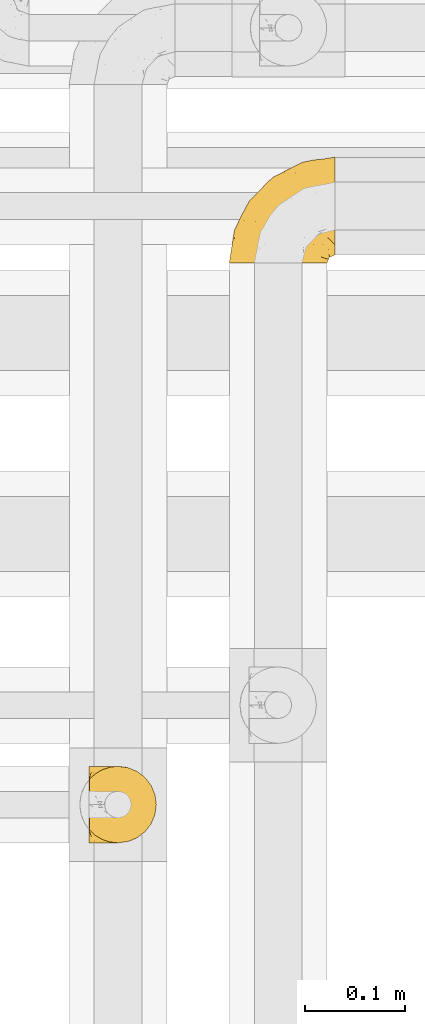
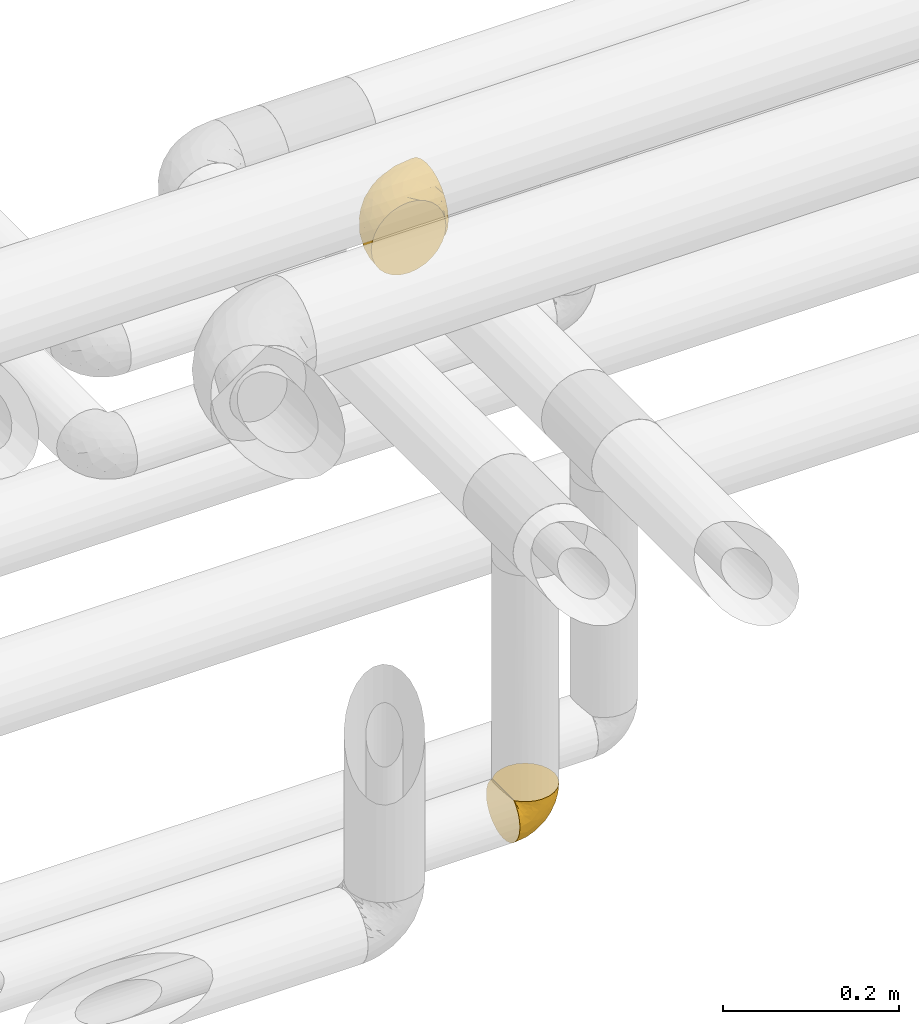
# One storey, part 363 of 827: 2 coverings.
"""IFC2X3 building model written with IfcOpenShell, lengths in millimetres."""

import ifcopenshell
import ifcopenshell.guid

model = None  # the IFC model being written
_history = None  # IfcOwnerHistory: only IFC2X3 demands one
_inside = {}  # id of a spatial element -> (the spatial element, [elements in it])
_under = {}  # id of a project, library or spatial element -> (it, [spatial elements below it])
_declared = {}  # id of a project -> (the project, [libraries it declares])
_typed = {}  # id of a type object -> (the type object, [elements of that type])
_made_of = {}  # id of a material, layer set ... -> (it, [elements and type objects made of it])


def new_model(schema):
    """Start an empty IFC model of exactly this schema.

    Asked for "IFC4X3", IfcOpenShell would pick the latest addendum, in which some entities
    have other attributes; the version numbers below select the first issue.
    IFC2X3 requires an IfcOwnerHistory on every rooted entity: one is made here for all.
    """
    global model, _history
    if schema == "IFC4X3":
        model = ifcopenshell.file(schema_version=(4, 3, 0, 0))
    else:
        model = ifcopenshell.file(schema=schema)
    _inside.clear()
    _under.clear()
    _declared.clear()
    _typed.clear()
    _made_of.clear()
    _history = None
    if model.schema == "IFC2X3":
        org = make("IfcOrganization", Name="unknown")
        user = make(
            "IfcPersonAndOrganization",
            ThePerson=make("IfcPerson", FamilyName="unknown"),
            TheOrganization=org,
        )
        app = make(
            "IfcApplication",
            ApplicationDeveloper=org,
            Version="unknown",
            ApplicationFullName="unknown",
            ApplicationIdentifier="unknown",
        )
        _history = make(
            "IfcOwnerHistory",
            OwningUser=user,
            OwningApplication=app,
            ChangeAction="ADDED",
            CreationDate=0,
        )
    return model


def make(cls, **values):
    """One entity of the class cls with the attributes given. An attribute that is None is left unset."""
    return model.create_entity(
        cls, **{name: value for name, value in values.items() if value is not None}
    )


def entity(cls, *values):
    """Any entity or typed value of the class cls, its attributes in the order of the schema. None: left unset."""
    e = model.create_entity(cls)
    for i, value in enumerate(values):
        if value is not None:
            e[i] = value
    return e


def rooted(cls, **values):
    """An entity with a GlobalId (a new one), such as an element, a storey or a relation."""
    return make(cls, GlobalId=ifcopenshell.guid.new(), OwnerHistory=_history, **values)


def si_unit(unit_type, name, prefix=None):
    """IfcSIUnit, for example si_unit("LENGTHUNIT", "METRE", prefix="MILLI")."""
    return make("IfcSIUnit", UnitType=unit_type, Prefix=prefix, Name=name)


def converted_unit(unit_type, name, factor, base, dimensions=None, offset=None):
    """IfcConversionBasedUnit, such as the inch: factor (a typed value) times the base unit."""
    return make(
        "IfcConversionBasedUnit"
        if offset is None
        else "IfcConversionBasedUnitWithOffset",
        ConversionOffset=offset,
        Dimensions=None
        if dimensions is None
        else entity("IfcDimensionalExponents", *dimensions),
        UnitType=unit_type,
        Name=name,
        ConversionFactor=make(
            "IfcMeasureWithUnit", ValueComponent=factor, UnitComponent=base
        ),
    )


def derived_unit(unit_type, elements):
    """IfcDerivedUnit: a product of units, each with its exponent."""
    return make(
        "IfcDerivedUnit",
        Elements=[
            make("IfcDerivedUnitElement", Unit=unit, Exponent=power)
            for unit, power in elements
        ],
        UnitType=unit_type,
    )


def assignment(units):
    """IfcUnitAssignment: the units of a project."""
    return None if units is None else make("IfcUnitAssignment", Units=units)


def point(xyz):
    """IfcCartesianPoint."""
    return None if xyz is None else make("IfcCartesianPoint", Coordinates=xyz)


def direction(xyz):
    """IfcDirection."""
    return None if xyz is None else make("IfcDirection", DirectionRatios=xyz)


def frame(location, z_axis=None, x_axis=None):
    """IfcAxis2Placement3D, a coordinate frame: its origin and axes. An axis left out is left unset."""
    return make(
        "IfcAxis2Placement3D",
        Location=point(location),
        Axis=direction(z_axis),
        RefDirection=direction(x_axis),
    )


def origin():
    """The frame at (0, 0, 0) with its axes left unset."""
    return frame((0.0, 0.0, 0.0))


def place(relative_to, where):
    """IfcLocalPlacement: puts the frame where relative to a parent placement (None: the world)."""
    return make(
        "IfcLocalPlacement", PlacementRelTo=relative_to, RelativePlacement=where
    )


def context(
    kind, dimensions, precision=None, world=None, true_north=None, identifier=None
):
    """IfcGeometricRepresentationContext, for example the 3D "Model" context."""
    return make(
        "IfcGeometricRepresentationContext",
        ContextIdentifier=identifier,
        ContextType=kind,
        CoordinateSpaceDimension=dimensions,
        Precision=precision,
        WorldCoordinateSystem=world,
        TrueNorth=true_north,
    )


def subcontext(parent, identifier, kind, view, scale=None):
    """IfcGeometricRepresentationSubContext, for example "Body" below "Model"."""
    return make(
        "IfcGeometricRepresentationSubContext",
        ContextIdentifier=identifier,
        ContextType=kind,
        ParentContext=parent,
        TargetScale=scale,
        TargetView=view,
    )


def project(units=None, contexts=None):
    """IfcProject with its units and contexts."""
    return rooted(
        "IfcProject",
        Name="project",
        RepresentationContexts=contexts,
        UnitsInContext=assignment(units),
    )


def spatial(cls, under=None, at=None, **own):
    """A site, building, storey or space (cls), placed at a placement, below another one or the project."""
    s = rooted(cls, ObjectPlacement=at, **own)
    if under is not None:
        _under.setdefault(under.id(), (under, []))[1].append(s)
    return s


def faces_of(points, faces, orient=None, outer=None):
    """IfcFace entities. A face is a list of loops; a loop is a list of indices into points, from 0.

    orient and outer hold one flag for each loop. By default every Orientation is true, the
    first loop of a face is its IfcFaceOuterBound and the others are IfcFaceBound.
    """
    made = []
    for i, loops in enumerate(faces):
        bounds = []
        for j, loop in enumerate(loops):
            is_outer = j == 0 if outer is None else outer[i][j]
            bounds.append(
                make(
                    "IfcFaceOuterBound" if is_outer else "IfcFaceBound",
                    Bound=make("IfcPolyLoop", Polygon=[points[k] for k in loop]),
                    Orientation=True if orient is None else orient[i][j],
                )
            )
        made.append(make("IfcFace", Bounds=bounds))
    return made


def faceted_brep(points, faces, orient=None, outer=None, voids=None):
    """IfcFacetedBrep: a solid bounded by flat faces; with voids (closed shells), ...WithVoids."""
    shared = [point(p) for p in points]
    hull = make("IfcClosedShell", CfsFaces=faces_of(shared, faces, orient, outer))
    if voids is None:
        return make("IfcFacetedBrep", Outer=hull)
    return make(
        "IfcFacetedBrepWithVoids",
        Outer=hull,
        Voids=[
            make(cls, CfsFaces=faces_of(shared, fs, o, b)) for cls, fs, o, b in voids
        ],
    )


def shape(context_of_items, identifier, shape_type, items):
    """IfcShapeRepresentation: the items that make up one representation, for example the "Body"."""
    return make(
        "IfcShapeRepresentation",
        ContextOfItems=context_of_items,
        RepresentationIdentifier=identifier,
        RepresentationType=shape_type,
        Items=items,
    )


def made_of(thing, what):
    """Note that an element or type object is made of a material, layer set ...; save() writes the relation."""
    if what is not None:
        _made_of.setdefault(what.id(), (what, []))[1].append(thing)
    return thing


def element(
    cls,
    number,
    at=None,
    inside=None,
    cuts=None,
    type_object=None,
    material=None,
    context=None,
    identifier="Body",
    shape_type=None,
    held_by="IfcProductDefinitionShape",
    body=None,
    shapes=None,
    **own,
):
    """One element of the class cls, such as IfcWall. Its Tag is "e" and its number.

    at: its placement. inside: the storey or other place that contains it. cuts: it is an
    opening in that element (IfcRelVoidsElement). A single representation is given by context,
    identifier, shape_type and body (its items); several are given by shapes. held_by: the class
    of the entity that holds the representations. save() writes the other relations.
    """
    e = rooted(cls, Tag="e%d" % number, ObjectPlacement=at, **own)
    if body is not None:
        shapes = [shape(context, identifier, shape_type, body)]
    if shapes is not None:
        e.Representation = make(held_by, Representations=shapes)
    if inside is not None:
        _inside.setdefault(inside.id(), (inside, []))[1].append(e)
    if cuts is not None:
        rooted(
            "IfcRelVoidsElement", RelatingBuildingElement=cuts, RelatedOpeningElement=e
        )
    if type_object is not None:
        _typed.setdefault(type_object.id(), (type_object, []))[1].append(e)
    return made_of(e, material)


def aggregate(whole, parts):
    """IfcRelAggregates: a whole, such as a stair, and the parts it consists of."""
    return rooted("IfcRelAggregates", RelatingObject=whole, RelatedObjects=parts)


def save(model, path):
    """Write the relations noted so far, then the file.

    IfcRelAggregates (storeys below a building ...), IfcRelContainedInSpatialStructure (elements
    in a storey), IfcRelDefinesByType, IfcRelAssociatesMaterial and IfcRelDeclares: one each for
    every whole, place, type object, material and project.
    """
    for whole, parts in _under.values():
        aggregate(whole, parts)
    for where, things in _inside.values():
        rooted(
            "IfcRelContainedInSpatialStructure",
            RelatedElements=things,
            RelatingStructure=where,
        )
    for kind, things in _typed.values():
        rooted("IfcRelDefinesByType", RelatedObjects=things, RelatingType=kind)
    for what, things in _made_of.values():
        rooted("IfcRelAssociatesMaterial", RelatedObjects=things, RelatingMaterial=what)
    for by, libraries in _declared.values():
        rooted("IfcRelDeclares", RelatingContext=by, RelatedDefinitions=libraries)
    model.write(path)


model = new_model("IFC2X3")

# Units and contexts
model_context = context("Model", 3, precision=0.01, world=origin(), true_north=direction((6.12303176911189e-17, 1.0)))
body_context = subcontext(model_context, "Body", "Model", "MODEL_VIEW")
ifc_project = project(units=[si_unit("LENGTHUNIT", "METRE", prefix="MILLI"), si_unit("AREAUNIT", "SQUARE_METRE"), si_unit("VOLUMEUNIT", "CUBIC_METRE"), converted_unit("PLANEANGLEUNIT", "DEGREE", entity("IfcRatioMeasure", 0.0174532925199433), si_unit("PLANEANGLEUNIT", "RADIAN"), dimensions=[0, 0, 0, 0, 0, 0, 0]), si_unit("MASSUNIT", "GRAM", prefix="KILO"), derived_unit("MASSDENSITYUNIT", [(si_unit("MASSUNIT", "GRAM", prefix="KILO"), 1), (si_unit("LENGTHUNIT", "METRE"), -3)]), derived_unit("MOMENTOFINERTIAUNIT", [(si_unit("LENGTHUNIT", "METRE"), 4)]), si_unit("TIMEUNIT", "SECOND"), si_unit("FREQUENCYUNIT", "HERTZ"), si_unit("THERMODYNAMICTEMPERATUREUNIT", "DEGREE_CELSIUS"), derived_unit("THERMALTRANSMITTANCEUNIT", [(si_unit("MASSUNIT", "GRAM", prefix="KILO"), 1), (si_unit("THERMODYNAMICTEMPERATUREUNIT", "KELVIN"), -1), (si_unit("TIMEUNIT", "SECOND"), -3)]), derived_unit("VOLUMETRICFLOWRATEUNIT", [(si_unit("LENGTHUNIT", "METRE"), 3), (si_unit("TIMEUNIT", "SECOND"), -1)]), derived_unit("MASSFLOWRATEUNIT", [(si_unit("MASSUNIT", "GRAM", prefix="KILO"), 1), (si_unit("TIMEUNIT", "SECOND"), -1)]), derived_unit("ROTATIONALFREQUENCYUNIT", [(si_unit("TIMEUNIT", "SECOND"), -1)]), si_unit("ELECTRICCURRENTUNIT", "AMPERE"), si_unit("ELECTRICVOLTAGEUNIT", "VOLT"), si_unit("POWERUNIT", "WATT"), si_unit("FORCEUNIT", "NEWTON", prefix="KILO"), si_unit("ILLUMINANCEUNIT", "LUX"), si_unit("LUMINOUSFLUXUNIT", "LUMEN"), si_unit("LUMINOUSINTENSITYUNIT", "CANDELA"), derived_unit("USERDEFINED", [(si_unit("MASSUNIT", "GRAM", prefix="KILO"), -1), (si_unit("LENGTHUNIT", "METRE"), -2), (si_unit("TIMEUNIT", "SECOND"), 3), (si_unit("LUMINOUSFLUXUNIT", "LUMEN"), 1)]), derived_unit("LINEARVELOCITYUNIT", [(si_unit("LENGTHUNIT", "METRE"), 1), (si_unit("TIMEUNIT", "SECOND"), -1)]), si_unit("PRESSUREUNIT", "PASCAL"), derived_unit("USERDEFINED", [(si_unit("LENGTHUNIT", "METRE"), -2), (si_unit("MASSUNIT", "GRAM", prefix="KILO"), 1), (si_unit("TIMEUNIT", "SECOND"), -2)]), derived_unit("LINEARFORCEUNIT", [(si_unit("MASSUNIT", "GRAM", prefix="KILO"), 1), (si_unit("LENGTHUNIT", "METRE"), 1), (si_unit("TIMEUNIT", "SECOND"), -2), (si_unit("LENGTHUNIT", "METRE"), -1)]), derived_unit("PLANARFORCEUNIT", [(si_unit("MASSUNIT", "GRAM", prefix="KILO"), 1), (si_unit("LENGTHUNIT", "METRE"), 1), (si_unit("TIMEUNIT", "SECOND"), -2), (si_unit("LENGTHUNIT", "METRE"), -2)])], contexts=[model_context])

# Site, building, storey
site_placement = place(None, origin())
site = spatial("IfcSite", under=ifc_project, at=site_placement, CompositionType="ELEMENT")
building_placement = place(site_placement, origin())
building = spatial("IfcBuilding", under=site, at=building_placement, CompositionType="ELEMENT")
storey_placement = place(building_placement, frame((0.0, 0.0, 28200.0)))
storey = spatial("IfcBuildingStorey", under=building, at=storey_placement, Name="08", CompositionType="ELEMENT", Elevation=28200.0)

# Coverings
covering_1_placement = place(storey_placement, frame((36438.02, 18294.87, 2960.12)))
element("IfcCovering", 1, at=covering_1_placement, inside=storey, Name=":ADSK_", ObjectType=":ADSK_", PredefinedType="INSULATION", context=body_context, shape_type="Brep", body=[
    faceted_brep([(1.6, 74.68, 23.36), (1.6, 70.1, 16.07), (1.6, 64.01, 9.98), (1.6, 56.72, 5.4), (1.6, 48.6, 2.56), (1.6, 40.05, 1.6), (1.6, 31.49, 2.56), (1.6, 23.36, 5.41), (1.6, 16.07, 9.99), (1.6, 9.98, 16.08), (1.6, 5.4, 23.37), (1.6, 2.56, 31.49), (1.6, 1.6, 40.05), (1.6, 2.46, 48.15), (1.6, 5.01, 55.88), (1.6, 9.13, 62.9), (1.6, 14.62, 68.89), (1.6, 16.82, 68.89), (1.6, 18.56, 68.89), (1.6, 20.52, 68.89), (1.6, 22.49, 68.89), (1.6, 24.46, 68.89), (1.6, 26.42, 68.89), (1.6, 28.39, 68.89), (1.6, 30.36, 68.89), (1.6, 32.55, 68.89), (1.6, 34.75, 68.89), (1.6, 36.94, 68.89), (1.6, 39.13, 68.89), (1.6, 41.33, 68.89), (1.6, 43.52, 68.89), (1.6, 45.72, 68.89), (1.6, 47.91, 68.89), (1.6, 50.11, 68.89), (1.6, 52.3, 68.89), (1.6, 54.49, 68.89), (1.6, 56.69, 68.89), (1.6, 58.88, 68.89), (1.6, 61.08, 68.89), (1.6, 63.27, 68.89), (1.6, 65.47, 68.89), (1.6, 70.97, 62.89), (1.6, 75.09, 55.86), (1.6, 77.64, 48.13), (1.6, 78.5, 40.05), (1.6, 77.53, 31.49), (1.85, 14.62, 69.15), (7.85, 9.12, 69.15), (14.87, 5.0, 69.15), (22.6, 2.46, 69.15), (30.7, 1.6, 69.15), (40.65, 2.91, 69.15), (49.92, 6.75, 69.15), (57.88, 12.86, 69.15), (63.99, 20.82, 69.15), (67.84, 30.09, 69.15), (69.15, 40.05, 69.15), (67.84, 50.0, 69.15), (63.99, 59.27, 69.15), (57.88, 67.23, 69.15), (49.92, 73.34, 69.15), (40.65, 77.19, 69.15), (30.7, 78.5, 69.15), (22.6, 77.63, 69.15), (14.87, 75.09, 69.15), (7.85, 70.97, 69.15), (1.85, 65.47, 69.15), (1.85, 63.27, 69.15), (1.85, 62.29, 69.15), (1.85, 60.7, 69.15), (1.85, 59.11, 69.15), (1.85, 57.52, 69.15), (1.85, 55.93, 69.15), (1.85, 54.34, 69.15), (1.85, 52.76, 69.15), (1.85, 51.17, 69.15), (1.85, 49.58, 69.15), (1.85, 47.99, 69.15), (1.85, 46.4, 69.15), (1.85, 44.81, 69.15), (1.85, 43.22, 69.15), (1.85, 41.63, 69.15), (1.85, 40.05, 69.15), (1.85, 38.46, 69.15), (1.85, 36.87, 69.15), (1.85, 35.28, 69.15), (1.85, 33.69, 69.15), (1.85, 32.1, 69.15), (1.85, 30.51, 69.15), (1.85, 28.92, 69.15), (1.85, 27.33, 69.15), (1.85, 25.37, 69.15), (1.85, 23.4, 69.15), (1.85, 21.21, 69.15), (1.85, 19.01, 69.15), (1.85, 16.82, 69.15), (1.77, 42.32, 68.96), (1.78, 44.02, 68.97), (1.77, 47.13, 68.97), (1.77, 48.74, 68.97), (1.76, 23.57, 68.95), (1.77, 25.13, 68.96), (1.79, 61.34, 68.98), (1.78, 22.02, 68.97), (1.78, 29.72, 68.97), (1.78, 56.73, 68.98), (1.78, 55.14, 68.97), (1.78, 37.66, 68.97), (1.74, 64.12, 68.94), (1.78, 28.13, 68.98), (1.78, 26.62, 68.98), (1.77, 31.46, 68.96), (1.78, 16.16, 68.97), (1.78, 39.16, 68.98), (1.78, 50.37, 68.98), (1.77, 17.69, 68.97), (1.77, 19.17, 68.96), (1.77, 62.78, 68.97), (1.78, 58.35, 68.97), (1.78, 45.53, 68.98), (1.77, 59.91, 68.96), (1.77, 65.47, 68.97), (1.72, 65.47, 68.94), (1.66, 65.47, 68.92), (1.77, 14.62, 68.97), (1.8, 14.62, 69.02), (1.82, 14.62, 69.08), (1.79, 20.59, 68.98), (1.78, 32.99, 68.97), (1.79, 34.48, 68.98), (1.78, 51.91, 68.97), (1.82, 65.47, 69.08), (1.8, 65.47, 69.02), (1.76, 53.48, 68.96), (1.66, 14.62, 68.92), (1.72, 14.62, 68.94), (1.78, 40.77, 68.97), (1.77, 35.97, 68.96), (9.41, 7.84, 67.02), (17.65, 3.53, 63.33), (7.41, 8.32, 64.61), (15.21, 2.19, 51.4), (7.41, 3.53, 53.1), (16.15, 1.6, 43.94), (28.75, 1.6, 61.87), (13.67, 4.57, 61.54), (12.79, 3.96, 57.95), (19.18, 2.28, 56.12), (29.16, 1.6, 63.4), (9.04, 7.69, 65.41), (5.74, 8.32, 63.04), (3.72, 7.84, 61.33), (8.87, 1.6, 41.99), (21.47, 1.6, 49.27), (26.8, 1.6, 54.6), (9.53, 4.34, 56.6), (7.34, 1.6, 41.58), (37.63, 29.63, 13.72), (17.92, 27.34, 5.82), (27.45, 40.05, 6.74), (37.01, 2.39, 58.82), (34.22, 2.43, 51.58), (45.87, 9.07, 42.09), (56.57, 16.64, 46.12), (52.31, 9.54, 55.56), (42.07, 4.52, 52.38), (44.74, 4.52, 61.54), (21.49, 7.49, 23.76), (11.02, 7.49, 20.5), (15.64, 12.85, 14.64), (26.02, 2.35, 41.77), (36.59, 22.66, 16.28), (65.49, 32.9, 49.4), (63.99, 25.33, 52.34), (15.2, 40.05, 4.3), (60.27, 16.64, 58.67), (45.25, 19.99, 25.26), (35.21, 16.37, 20.17), (22.52, 3.26, 34.7), (12.03, 3.75, 28.67), (13.32, 19.58, 8.62), (35.9, 7.5, 33.37), (33.87, 4.04, 41.35), (25.73, 13.94, 17.15), (26.34, 19.58, 12.68), (46.78, 28.21, 21.47), (59.54, 24.75, 41.11), (60.18, 31.42, 37.53), (53.93, 26.2, 30.64), (53.36, 33.36, 26.66), (49.36, 40.05, 21.38), (38.4, 40.05, 14.06), (66.44, 40.05, 55.54), (50.09, 16.14, 35.17), (41.08, 12.85, 29.04), (31.14, 10.47, 24.34), (28.19, 6.49, 29.33), (64.0, 40.05, 43.3), (56.68, 40.05, 32.34), (43.9, 75.57, 57.75), (65.46, 47.37, 49.41), (52.22, 52.91, 27.85), (37.61, 50.46, 13.7), (15.64, 67.23, 14.63), (13.31, 60.5, 8.61), (50.02, 70.55, 48.85), (59.28, 63.45, 54.13), (53.05, 62.61, 37.84), (21.48, 72.6, 23.75), (11.01, 72.6, 20.49), (12.03, 76.34, 28.66), (41.02, 59.34, 20.83), (35.39, 77.76, 55.15), (26.8, 78.5, 54.6), (28.75, 78.5, 61.87), (7.34, 78.5, 41.58), (65.81, 53.16, 57.58), (53.28, 70.55, 59.91), (59.8, 48.88, 36.94), (61.82, 54.76, 45.72), (17.91, 52.74, 5.82), (41.4, 71.93, 37.91), (40.48, 75.79, 50.18), (26.34, 60.5, 12.67), (31.68, 77.86, 49.29), (27.68, 77.64, 42.64), (16.15, 78.5, 43.94), (21.47, 78.5, 49.27), (28.05, 67.23, 19.45), (22.54, 76.82, 34.7), (8.87, 78.5, 41.99), (37.3, 77.8, 62.29), (41.07, 67.23, 29.01), (32.24, 73.2, 31.47), (47.4, 67.66, 37.18), (35.77, 75.99, 43.45), (17.65, 76.57, 63.33), (11.06, 73.21, 67.23), (8.55, 71.93, 66.07), (6.63, 71.07, 65.22), (12.77, 75.09, 61.99), (12.79, 76.13, 57.95), (7.41, 76.57, 53.09), (18.97, 77.69, 56.84), (3.72, 72.26, 61.33), (5.76, 71.77, 63.06), (15.21, 77.9, 51.41), (9.52, 75.75, 56.61)], [[[0, 1, 2, 3, 4, 5, 6, 7, 8, 9, 10, 11, 12, 13, 14, 15, 16, 17, 18, 19, 20, 21, 22, 23, 24, 25, 26, 27, 28, 29, 30, 31, 32, 33, 34, 35, 36, 37, 38, 39, 40, 41, 42, 43, 44, 45]], [[46, 47, 48, 49, 50, 51, 52, 53, 54, 55, 56, 57, 58, 59, 60, 61, 62, 63, 64, 65, 66, 67, 68, 69, 70, 71, 72, 73, 74, 75, 76, 77, 78, 79, 80, 81, 82, 83, 84, 85, 86, 87, 88, 89, 90, 91, 92, 93, 94, 95]], [[96, 97, 30]], [[98, 77, 99]], [[100, 101, 21]], [[69, 68, 102]], [[20, 19, 103]], [[24, 23, 104]], [[20, 103, 100]], [[72, 105, 106]], [[84, 83, 107]], [[89, 88, 104]], [[108, 67, 66]], [[109, 110, 90]], [[111, 25, 24]], [[112, 17, 16]], [[82, 113, 83]], [[109, 23, 22]], [[114, 76, 75]], [[105, 36, 106]], [[104, 111, 24]], [[18, 115, 116]], [[97, 96, 80]], [[67, 108, 117]], [[105, 71, 118]], [[31, 97, 119]], [[102, 120, 69]], [[108, 121, 122, 123, 40]], [[112, 95, 115]], [[17, 115, 18]], [[94, 116, 115]], [[117, 68, 67]], [[38, 117, 39]], [[112, 124, 125, 126, 46]], [[17, 112, 115]], [[70, 120, 118]], [[39, 117, 108]], [[120, 38, 37]], [[120, 37, 118]], [[120, 70, 69]], [[116, 94, 127]], [[128, 86, 129]], [[117, 38, 102]], [[74, 130, 75]], [[99, 33, 32]], [[115, 95, 94]], [[39, 108, 40]], [[108, 66, 131, 132, 121]], [[105, 72, 71]], [[118, 37, 36]], [[71, 70, 118]], [[35, 106, 36]], [[36, 105, 118]], [[35, 133, 106]], [[74, 73, 133]], [[106, 133, 73]], [[99, 114, 33]], [[133, 35, 34]], [[73, 72, 106]], [[95, 112, 46]], [[112, 16, 134, 135, 124]], [[130, 114, 75]], [[99, 76, 114]], [[114, 130, 33]], [[34, 33, 130]], [[78, 77, 98]], [[98, 119, 78]], [[130, 133, 34]], [[133, 130, 74]], [[79, 97, 80]], [[98, 99, 32]], [[98, 32, 31]], [[77, 76, 99]], [[97, 79, 119]], [[136, 96, 29]], [[30, 97, 31]], [[136, 29, 28]], [[81, 80, 96]], [[29, 96, 30]], [[31, 119, 98]], [[119, 79, 78]], [[96, 136, 81]], [[82, 81, 136]], [[113, 107, 83]], [[84, 107, 137]], [[107, 27, 137]], [[113, 28, 107]], [[27, 107, 28]], [[85, 84, 137]], [[137, 27, 26]], [[113, 136, 28]], [[136, 113, 82]], [[109, 89, 104]], [[86, 85, 129]], [[89, 109, 90]], [[111, 87, 128]], [[26, 129, 137]], [[88, 111, 104]], [[25, 111, 128]], [[22, 110, 109]], [[23, 109, 104]], [[110, 91, 90]], [[100, 92, 101]], [[110, 22, 101]], [[91, 110, 101]], [[116, 19, 18]], [[111, 88, 87]], [[127, 103, 19]], [[25, 128, 26]], [[86, 128, 87]], [[128, 129, 26]], [[137, 129, 85]], [[120, 102, 38]], [[117, 102, 68]], [[91, 101, 92]], [[21, 101, 22]], [[93, 92, 103]], [[100, 21, 20]], [[100, 103, 92]], [[127, 93, 103]], [[93, 127, 94]], [[116, 127, 19]], [[126, 138, 47]], [[48, 138, 139]], [[140, 125, 124]], [[141, 142, 143]], [[144, 49, 139]], [[145, 140, 146]], [[48, 139, 49]], [[139, 145, 147]], [[49, 144, 148, 50]], [[126, 125, 149]], [[14, 13, 142]], [[150, 146, 140]], [[149, 140, 145]], [[151, 150, 135]], [[151, 14, 142]], [[16, 15, 134]], [[13, 152, 142]], [[124, 150, 140]], [[141, 143, 153]], [[14, 151, 15]], [[15, 151, 134]], [[47, 46, 126]], [[139, 154, 144]], [[138, 48, 47]], [[125, 140, 149]], [[135, 134, 151]], [[146, 155, 141]], [[145, 146, 147]], [[149, 139, 138]], [[147, 153, 154]], [[147, 146, 141]], [[139, 147, 154]], [[139, 149, 145]], [[149, 138, 126]], [[147, 141, 153]], [[146, 150, 155]], [[151, 155, 150]], [[142, 141, 155]], [[13, 12, 156, 152]], [[152, 143, 142]], [[151, 142, 155]], [[150, 124, 135]], [[157, 158, 159]], [[160, 154, 161]], [[162, 163, 164]], [[165, 166, 160]], [[167, 168, 169]], [[153, 170, 161]], [[156, 12, 11]], [[158, 157, 171]], [[172, 55, 173]], [[158, 6, 174]], [[175, 54, 53]], [[52, 166, 164]], [[52, 164, 53]], [[54, 175, 173]], [[166, 52, 51]], [[176, 177, 171]], [[178, 143, 179]], [[156, 11, 179]], [[8, 7, 180]], [[169, 9, 8]], [[179, 143, 152, 156]], [[179, 11, 10]], [[168, 179, 10]], [[181, 162, 182]], [[179, 167, 178]], [[183, 184, 177]], [[183, 169, 184]], [[176, 171, 185]], [[172, 186, 187]], [[158, 7, 6]], [[159, 158, 174]], [[184, 180, 158]], [[54, 173, 55]], [[180, 169, 8]], [[188, 189, 187]], [[9, 168, 10]], [[186, 188, 187]], [[190, 157, 159, 191]], [[55, 172, 192]], [[176, 193, 194]], [[161, 170, 182]], [[162, 164, 165]], [[175, 164, 163]], [[51, 50, 148]], [[167, 195, 196]], [[178, 182, 170]], [[6, 5, 174]], [[158, 180, 7]], [[169, 180, 184]], [[169, 168, 9]], [[179, 168, 167]], [[182, 162, 165]], [[162, 194, 193]], [[161, 165, 160]], [[195, 181, 196]], [[192, 172, 197]], [[192, 56, 55]], [[189, 190, 198]], [[198, 197, 187]], [[172, 187, 197]], [[185, 189, 188]], [[198, 187, 189]], [[186, 172, 173]], [[173, 163, 186]], [[193, 186, 163]], [[176, 185, 188]], [[185, 157, 190]], [[188, 186, 193]], [[177, 176, 194]], [[188, 193, 176]], [[162, 193, 163]], [[195, 177, 194]], [[171, 177, 184]], [[181, 195, 194]], [[183, 167, 169]], [[162, 181, 194]], [[196, 182, 178]], [[158, 171, 184]], [[171, 157, 185]], [[177, 195, 183]], [[167, 183, 195]], [[182, 196, 181]], [[178, 170, 143]], [[178, 167, 196]], [[164, 175, 53]], [[173, 175, 163]], [[160, 51, 148]], [[164, 166, 165]], [[51, 160, 166]], [[160, 148, 144, 154]], [[153, 161, 154]], [[182, 165, 161]], [[190, 189, 185]], [[143, 170, 153]], [[60, 199, 61]], [[197, 200, 192]], [[201, 190, 202]], [[200, 57, 192]], [[203, 204, 2]], [[205, 206, 207]], [[208, 209, 210]], [[211, 207, 201]], [[212, 213, 214]], [[45, 215, 210]], [[216, 206, 58]], [[45, 44, 215]], [[59, 217, 60]], [[60, 217, 199]], [[0, 45, 210]], [[218, 201, 219]], [[202, 159, 220]], [[205, 221, 222]], [[223, 204, 203]], [[1, 203, 2]], [[57, 200, 216]], [[220, 3, 204]], [[220, 174, 4]], [[1, 0, 209]], [[212, 224, 213]], [[225, 226, 227]], [[228, 223, 203]], [[208, 210, 229]], [[210, 226, 229]], [[3, 220, 4]], [[58, 206, 59]], [[209, 203, 1]], [[202, 220, 223]], [[228, 203, 208]], [[202, 211, 201]], [[3, 2, 204]], [[202, 190, 191, 159]], [[210, 215, 230, 226]], [[199, 212, 231]], [[232, 233, 221]], [[233, 208, 229]], [[207, 206, 219]], [[217, 206, 205]], [[227, 224, 225]], [[233, 232, 228]], [[201, 207, 219]], [[234, 232, 221]], [[218, 219, 200]], [[202, 223, 211]], [[174, 220, 159]], [[174, 5, 4]], [[61, 231, 62]], [[220, 204, 223]], [[210, 209, 0]], [[203, 209, 208]], [[225, 233, 229]], [[224, 227, 213]], [[221, 233, 235]], [[57, 56, 192]], [[198, 218, 197]], [[200, 219, 216]], [[201, 198, 190]], [[197, 218, 200]], [[198, 201, 218]], [[206, 216, 219]], [[58, 57, 216]], [[231, 212, 214]], [[222, 212, 199]], [[228, 211, 223]], [[207, 211, 232]], [[62, 231, 214]], [[199, 231, 61]], [[233, 228, 208]], [[211, 228, 232]], [[222, 221, 235]], [[234, 205, 207]], [[206, 217, 59]], [[199, 217, 205]], [[205, 222, 199]], [[224, 222, 235]], [[222, 224, 212]], [[224, 235, 225]], [[233, 225, 235]], [[226, 225, 229]], [[205, 234, 221]], [[207, 232, 234]], [[63, 214, 236]], [[214, 213, 236]], [[214, 63, 62]], [[237, 236, 238]], [[238, 132, 131]], [[236, 237, 64]], [[239, 240, 241]], [[63, 236, 64]], [[131, 66, 65]], [[237, 131, 65]], [[242, 230, 43]], [[237, 65, 64]], [[239, 121, 132]], [[42, 242, 43]], [[241, 240, 243]], [[41, 123, 244]], [[43, 230, 215, 44]], [[244, 122, 245]], [[227, 246, 243]], [[241, 247, 245]], [[121, 239, 245]], [[41, 40, 123]], [[132, 238, 239]], [[244, 42, 41]], [[131, 237, 238]], [[240, 239, 238]], [[245, 239, 241]], [[247, 241, 246]], [[247, 244, 245]], [[238, 236, 240]], [[243, 236, 213]], [[236, 243, 240]], [[227, 226, 246]], [[243, 213, 227]], [[242, 246, 226]], [[243, 246, 241]], [[246, 242, 247]], [[244, 247, 242]], [[242, 226, 230]], [[42, 244, 242]], [[122, 244, 123]], [[122, 121, 245]]]),
])
covering_2_placement = place(storey_placement, frame((36578.9, 18877.81, 3349.15)))
element("IfcCovering", 2, at=covering_2_placement, inside=storey, Name=":ADSK_", ObjectType=":ADSK_", PredefinedType="INSULATION", context=body_context, shape_type="Brep", body=[
    faceted_brep([(50.75, 1.6, 99.9), (39.8, 1.6, 98.66), (29.41, 1.6, 95.02), (20.09, 1.6, 89.17), (12.31, 1.6, 81.38), (6.46, 1.6, 72.06), (2.83, 1.6, 61.68), (1.6, 1.6, 50.75), (2.83, 1.6, 39.8), (6.47, 1.6, 29.41), (12.32, 1.6, 20.09), (20.11, 1.6, 12.31), (29.43, 1.6, 6.46), (39.81, 1.6, 2.83), (50.75, 1.6, 1.6), (56.45, 1.6, 2.24), (61.69, 1.6, 2.83), (66.88, 1.6, 4.65), (72.08, 1.6, 6.47), (81.4, 1.6, 12.32), (89.18, 1.6, 20.11), (95.03, 1.6, 29.43), (98.66, 1.6, 39.81), (99.9, 1.6, 50.75), (98.66, 1.6, 61.69), (95.02, 1.6, 72.08), (89.17, 1.6, 81.4), (81.38, 1.6, 89.18), (72.06, 1.6, 95.03), (66.87, 1.6, 96.85), (61.68, 1.6, 98.66), (56.45, 1.6, 99.25), (53.6, 1.6, 99.57), (107.75, 11.12, 38.02), (107.75, 16.03, 26.17), (107.75, 19.94, 21.08), (107.75, 23.84, 15.99), (107.75, 28.93, 12.09), (107.75, 34.02, 8.18), (107.75, 39.95, 5.73), (107.75, 45.87, 3.27), (107.75, 52.86, 2.35), (107.75, 55.73, 1.97), (107.75, 58.6, 1.6), (107.75, 71.32, 3.27), (107.75, 83.17, 8.18), (107.75, 93.35, 15.99), (107.75, 101.16, 26.17), (107.75, 106.07, 38.02), (107.75, 107.75, 50.75), (107.75, 106.07, 63.47), (107.75, 101.16, 75.32), (107.75, 93.35, 85.5), (107.75, 83.17, 93.31), (107.75, 71.32, 98.22), (107.75, 58.6, 99.9), (107.75, 52.86, 99.14), (107.75, 45.87, 98.22), (107.75, 39.95, 95.77), (107.75, 34.02, 93.31), (107.75, 28.93, 89.4), (107.75, 23.84, 85.5), (107.75, 19.94, 80.41), (107.75, 16.03, 75.32), (107.75, 11.12, 63.47), (107.75, 9.45, 50.75), (39.38, 81.82, 59.31), (49.75, 84.02, 73.08), (57.38, 93.05, 63.72), (74.94, 102.55, 50.75), (85.97, 104.83, 58.64), (95.66, 105.83, 50.75), (67.82, 91.87, 76.74), (83.09, 101.74, 67.68), (89.16, 97.07, 78.92), (37.01, 38.45, 94.31), (43.46, 22.17, 98.76), (51.79, 42.04, 98.4), (85.58, 77.69, 94.57), (62.84, 75.76, 89.91), (62.77, 62.11, 96.32), (88.17, 66.08, 98.79), (85.93, 54.26, 99.9), (91.42, 55.35, 99.9), (96.91, 56.44, 99.9), (99.62, 56.98, 99.9), (102.33, 57.52, 99.9), (82.57, 87.84, 87.31), (32.75, 19.41, 95.61), (13.79, 48.89, 60.43), (6.77, 26.34, 65.24), (16.46, 44.55, 72.87), (55.08, 23.41, 99.9), (58.17, 28.03, 99.9), (61.26, 32.65, 99.9), (64.35, 37.28, 99.9), (67.44, 41.9, 99.9), (24.18, 20.6, 90.65), (23.37, 63.36, 63.14), (49.76, 62.21, 91.89), (9.84, 19.94, 75.25), (3.51, 13.68, 50.75), (55.75, 80.85, 82.18), (42.34, 66.53, 85.08), (37.78, 71.06, 76.93), (21.87, 63.99, 50.75), (33.61, 75.73, 50.75), (17.1, 26.77, 83.02), (51.28, 4.31, 99.9), (51.82, 7.01, 99.9), (52.9, 12.43, 99.9), (53.99, 17.92, 99.9), (28.01, 43.43, 87.13), (28.99, 56.23, 80.85), (69.9, 54.97, 99.17), (6.79, 34.4, 50.75), (72.06, 44.99, 99.9), (76.69, 48.08, 99.9), (81.31, 51.17, 99.9), (45.35, 87.47, 50.75), (34.79, 74.55, 67.61), (25.72, 60.86, 72.25), (14.33, 49.19, 50.75), (60.15, 95.01, 50.75), (62.38, 10.27, 98.69), (100.57, 48.79, 99.01), (91.06, 45.16, 98.79), (97.66, 44.99, 98.29), (97.55, 6.17, 68.51), (93.65, 7.65, 76.82), (66.85, 21.59, 98.54), (61.93, 19.96, 99.3), (101.4, 21.0, 83.57), (100.07, 27.2, 89.47), (101.36, 14.83, 75.76), (95.94, 19.7, 84.86), (96.3, 10.93, 75.89), (101.98, 9.63, 64.77), (85.88, 19.97, 90.83), (78.88, 21.13, 94.62), (82.8, 14.14, 90.37), (102.58, 30.2, 91.18), (82.88, 8.12, 88.65), (88.57, 9.93, 84.11), (88.67, 24.62, 91.75), (69.08, 11.87, 96.86), (102.19, 7.15, 50.75), (100.06, 5.32, 58.97), (70.56, 26.68, 98.37), (91.07, 13.92, 83.91), (77.56, 30.67, 97.52), (96.59, 36.65, 95.55), (86.38, 42.89, 98.76), (91.79, 34.04, 95.26), (81.71, 36.6, 98.04), (94.11, 26.41, 90.65), (76.09, 10.07, 93.51), (76.91, 15.83, 94.16), (81.44, 41.99, 99.1), (101.37, 14.83, 25.73), (94.12, 26.4, 10.84), (101.41, 21.01, 17.92), (95.96, 19.71, 16.64), (96.22, 5.72, 30.44), (66.85, 21.6, 2.95), (61.94, 19.96, 2.19), (58.17, 28.03, 1.6), (69.1, 11.87, 4.63), (88.58, 9.93, 17.39), (96.91, 56.44, 1.6), (102.33, 57.52, 1.6), (105.04, 58.06, 1.6), (82.9, 8.13, 12.86), (82.82, 14.15, 11.13), (97.66, 44.99, 3.2), (96.59, 36.65, 5.94), (100.07, 27.21, 12.02), (91.79, 34.04, 6.23), (102.58, 30.2, 10.31), (76.13, 10.06, 8.0), (76.93, 15.83, 7.34), (100.57, 48.79, 2.48), (86.38, 42.89, 2.73), (90.86, 45.38, 2.64), (52.9, 12.43, 1.6), (62.39, 10.28, 2.8), (101.98, 9.64, 36.71), (91.42, 55.35, 1.6), (85.93, 54.26, 1.6), (99.49, 6.05, 38.59), (51.82, 7.01, 1.6), (52.36, 9.72, 1.6), (61.26, 32.65, 1.6), (70.56, 26.68, 3.12), (91.09, 13.92, 17.59), (64.35, 37.28, 1.6), (77.6, 30.66, 3.98), (78.89, 21.14, 6.87), (81.71, 36.59, 3.45), (88.69, 24.6, 9.76), (53.99, 17.92, 1.6), (55.08, 23.41, 1.6), (96.31, 10.93, 25.62), (85.9, 19.97, 10.67), (81.45, 41.99, 2.39), (76.69, 48.08, 1.6), (81.31, 51.17, 1.6), (72.06, 44.99, 1.6), (67.44, 41.9, 1.6), (69.6, 55.26, 2.4), (85.97, 104.83, 42.85), (82.57, 87.84, 14.18), (63.16, 75.91, 11.56), (55.81, 80.84, 19.27), (67.81, 91.87, 24.75), (49.73, 83.98, 28.37), (32.55, 19.16, 5.95), (43.23, 22.37, 2.79), (88.17, 66.08, 2.71), (57.38, 93.05, 37.78), (83.08, 101.74, 33.81), (89.16, 97.07, 22.57), (85.58, 77.69, 6.92), (16.46, 44.55, 28.61), (6.77, 26.34, 36.24), (13.8, 48.9, 41.05), (37.71, 70.99, 24.55), (34.8, 74.55, 33.88), (36.83, 37.8, 7.11), (39.38, 81.82, 42.18), (17.12, 26.77, 18.46), (24.19, 20.6, 10.84), (28.89, 56.15, 20.69), (25.69, 60.85, 29.27), (51.77, 42.06, 3.1), (45.66, 57.03, 9.18), (23.39, 63.4, 38.38), (9.85, 19.94, 26.23), (28.11, 43.59, 14.34), (62.27, 62.61, 5.46), (42.35, 66.52, 16.39)], [[[0, 1, 2, 3, 4, 5, 6, 7, 8, 9, 10, 11, 12, 13, 14, 15, 16, 17, 18, 19, 20, 21, 22, 23, 24, 25, 26, 27, 28, 29, 30, 31, 32]], [[33, 34, 35, 36, 37, 38, 39, 40, 41, 42, 43, 44, 45, 46, 47, 48, 49, 50, 51, 52, 53, 54, 55, 56, 57, 58, 59, 60, 61, 62, 63, 64, 65]], [[66, 67, 68]], [[69, 70, 71]], [[68, 72, 73]], [[73, 72, 74]], [[75, 76, 77]], [[78, 79, 80]], [[51, 50, 73]], [[81, 82, 83, 84, 85, 86, 55]], [[52, 87, 53]], [[74, 52, 51]], [[2, 1, 88]], [[89, 90, 91]], [[77, 92, 93, 94, 95, 96]], [[55, 54, 81]], [[78, 53, 87]], [[5, 90, 6]], [[88, 76, 75]], [[97, 3, 2]], [[89, 91, 98]], [[99, 80, 79]], [[90, 5, 100]], [[74, 87, 52]], [[100, 5, 4]], [[90, 101, 6]], [[79, 102, 103]], [[102, 67, 104]], [[105, 98, 106]], [[107, 4, 3]], [[76, 0, 108, 109, 110, 111, 92]], [[107, 112, 113]], [[114, 77, 96]], [[89, 115, 90]], [[114, 96, 116, 117, 118, 82]], [[75, 97, 88]], [[119, 66, 68]], [[50, 71, 70]], [[100, 91, 90]], [[99, 77, 80]], [[102, 104, 103]], [[97, 107, 3]], [[80, 81, 78]], [[107, 97, 112]], [[68, 73, 70]], [[66, 98, 120]], [[78, 81, 54]], [[114, 81, 80]], [[53, 78, 54]], [[78, 87, 79]], [[102, 87, 72]], [[79, 103, 99]], [[4, 107, 100]], [[91, 100, 107]], [[88, 97, 2]], [[112, 97, 75]], [[99, 112, 75]], [[103, 104, 113]], [[91, 121, 98]], [[89, 105, 122, 115]], [[101, 90, 115]], [[101, 7, 6]], [[88, 1, 76]], [[0, 76, 1]], [[92, 77, 76]], [[73, 74, 51]], [[87, 74, 72]], [[81, 114, 82]], [[77, 114, 80]], [[87, 102, 79]], [[67, 102, 72]], [[68, 67, 72]], [[67, 120, 104]], [[120, 121, 104]], [[104, 121, 113]], [[121, 120, 98]], [[91, 107, 113]], [[91, 113, 121]], [[103, 113, 112]], [[106, 98, 66]], [[105, 89, 98]], [[106, 66, 119]], [[67, 66, 120]], [[68, 69, 123, 119]], [[50, 49, 71]], [[50, 70, 73]], [[112, 99, 103]], [[77, 99, 75]], [[69, 68, 70]], [[29, 124, 110]], [[84, 83, 125]], [[126, 82, 118]], [[59, 58, 127]], [[25, 128, 129]], [[130, 93, 131]], [[132, 62, 133]], [[134, 135, 136]], [[137, 65, 64]], [[64, 134, 137]], [[138, 139, 140]], [[111, 110, 124, 92]], [[134, 136, 137]], [[134, 64, 63]], [[141, 61, 60]], [[125, 58, 57]], [[142, 143, 140]], [[142, 26, 143]], [[127, 83, 82]], [[28, 124, 29]], [[108, 0, 32, 31, 30, 110, 109]], [[30, 29, 110]], [[135, 144, 138]], [[28, 145, 124]], [[57, 56, 55, 86, 85, 84]], [[146, 147, 23]], [[24, 23, 147]], [[25, 143, 26]], [[95, 94, 148]], [[24, 128, 25]], [[149, 138, 143]], [[124, 145, 131]], [[127, 58, 125]], [[150, 148, 139]], [[127, 126, 151]], [[151, 59, 127]], [[152, 151, 126]], [[153, 154, 155]], [[153, 133, 141]], [[145, 28, 27]], [[142, 156, 27]], [[157, 148, 130]], [[61, 133, 62]], [[134, 132, 135]], [[147, 128, 24]], [[65, 137, 146]], [[146, 137, 147]], [[128, 137, 136]], [[137, 128, 147]], [[128, 136, 129]], [[149, 129, 136]], [[25, 129, 143]], [[158, 152, 117]], [[152, 118, 117]], [[153, 151, 152]], [[158, 116, 154]], [[144, 150, 138]], [[153, 152, 158]], [[133, 153, 155]], [[133, 155, 132]], [[60, 151, 141]], [[135, 132, 155]], [[134, 63, 132]], [[144, 135, 155]], [[135, 138, 149]], [[155, 154, 144]], [[150, 154, 96]], [[154, 150, 144]], [[148, 94, 130]], [[82, 126, 127]], [[118, 152, 126]], [[150, 96, 95]], [[139, 148, 157]], [[150, 95, 148]], [[93, 92, 131]], [[130, 145, 156]], [[130, 94, 93]], [[84, 125, 57]], [[127, 125, 83]], [[140, 139, 157]], [[150, 139, 138]], [[140, 157, 142]], [[138, 140, 143]], [[156, 142, 157]], [[27, 26, 142]], [[130, 156, 157]], [[145, 27, 156]], [[132, 63, 62]], [[124, 131, 92]], [[130, 131, 145]], [[129, 149, 143]], [[135, 149, 136]], [[141, 133, 61]], [[60, 59, 151]], [[141, 151, 153]], [[116, 96, 154]], [[153, 158, 154]], [[158, 117, 116]], [[34, 33, 159]], [[160, 161, 162]], [[22, 21, 163]], [[164, 165, 166]], [[19, 18, 167]], [[168, 21, 20]], [[42, 41, 40, 169, 170, 171, 43]], [[172, 173, 168]], [[174, 38, 175]], [[176, 177, 178]], [[179, 164, 180]], [[40, 181, 169]], [[182, 183, 175]], [[17, 184, 185]], [[65, 146, 186]], [[187, 174, 188]], [[23, 22, 189]], [[174, 39, 38]], [[15, 14, 190, 191, 184, 16]], [[181, 40, 39]], [[192, 193, 164]], [[194, 163, 168]], [[33, 186, 159]], [[180, 173, 172]], [[195, 196, 193]], [[18, 185, 167]], [[173, 180, 197]], [[198, 199, 196]], [[200, 201, 185, 184]], [[184, 17, 16]], [[18, 17, 185]], [[202, 159, 186]], [[194, 168, 203]], [[189, 163, 202]], [[204, 205, 182]], [[187, 181, 174]], [[160, 177, 176]], [[206, 183, 182]], [[206, 182, 205]], [[201, 165, 185]], [[165, 164, 167]], [[172, 179, 180]], [[202, 194, 162]], [[176, 161, 160]], [[65, 186, 33]], [[163, 189, 22]], [[175, 177, 182]], [[174, 183, 188]], [[177, 198, 204]], [[199, 160, 162]], [[198, 207, 204]], [[175, 38, 37]], [[198, 177, 160]], [[178, 177, 175]], [[176, 35, 161]], [[34, 159, 161]], [[162, 161, 159]], [[202, 162, 159]], [[199, 162, 203]], [[196, 199, 203]], [[198, 160, 199]], [[193, 197, 180]], [[208, 198, 196]], [[188, 183, 206]], [[175, 183, 174]], [[193, 192, 195]], [[195, 208, 196]], [[197, 196, 203]], [[180, 164, 193]], [[168, 163, 21]], [[166, 165, 201]], [[166, 192, 164]], [[189, 202, 186]], [[186, 146, 189]], [[23, 189, 146]], [[174, 181, 39]], [[169, 181, 187]], [[196, 197, 193]], [[173, 203, 168]], [[203, 173, 197]], [[172, 168, 20]], [[20, 19, 172]], [[179, 172, 19]], [[19, 167, 179]], [[164, 179, 167]], [[35, 176, 36]], [[35, 34, 161]], [[185, 165, 167]], [[162, 194, 203]], [[163, 194, 202]], [[176, 178, 36]], [[37, 36, 178]], [[175, 37, 178]], [[177, 204, 182]], [[207, 198, 208]], [[207, 205, 204]], [[209, 188, 206, 205, 207, 208]], [[48, 210, 71]], [[211, 212, 213]], [[214, 213, 215]], [[216, 217, 13]], [[218, 43, 171, 170, 169, 187, 188]], [[219, 220, 214]], [[47, 46, 221]], [[210, 48, 220]], [[211, 222, 212]], [[222, 45, 44]], [[221, 220, 47]], [[47, 220, 48]], [[221, 211, 214]], [[223, 224, 225]], [[211, 46, 45]], [[226, 227, 215]], [[43, 218, 44]], [[217, 216, 228]], [[219, 215, 229]], [[14, 13, 217]], [[224, 9, 8]], [[10, 230, 11]], [[11, 231, 12]], [[232, 223, 233]], [[234, 208, 195, 192, 166, 201]], [[235, 234, 228]], [[222, 44, 218]], [[106, 229, 236]], [[224, 237, 9]], [[231, 238, 228]], [[9, 237, 10]], [[115, 224, 101]], [[239, 234, 235]], [[231, 11, 230]], [[223, 230, 237]], [[224, 8, 101]], [[223, 236, 233]], [[225, 115, 122, 105]], [[216, 12, 231]], [[209, 234, 239]], [[210, 219, 69]], [[219, 214, 215]], [[229, 119, 219]], [[209, 218, 188]], [[239, 212, 222]], [[239, 222, 218]], [[45, 222, 211]], [[235, 212, 239]], [[213, 212, 240]], [[223, 237, 224]], [[230, 10, 237]], [[238, 231, 230]], [[216, 231, 228]], [[232, 230, 223]], [[235, 238, 240]], [[115, 225, 224]], [[233, 236, 227]], [[8, 7, 101]], [[234, 209, 208]], [[218, 209, 239]], [[217, 228, 234]], [[13, 12, 216]], [[234, 201, 217]], [[217, 201, 200, 184, 191, 190, 14]], [[211, 221, 46]], [[220, 221, 214]], [[71, 210, 69]], [[71, 49, 48]], [[219, 210, 220]], [[226, 215, 213]], [[211, 213, 214]], [[226, 213, 240]], [[215, 227, 229]], [[232, 240, 238]], [[233, 227, 226]], [[232, 233, 226]], [[236, 223, 225]], [[240, 232, 226]], [[232, 238, 230]], [[225, 105, 236]], [[236, 105, 106]], [[236, 229, 227]], [[123, 69, 219, 119]], [[106, 119, 229]], [[238, 235, 228]], [[212, 235, 240]]]),
])

save(model, "model.ifc")
